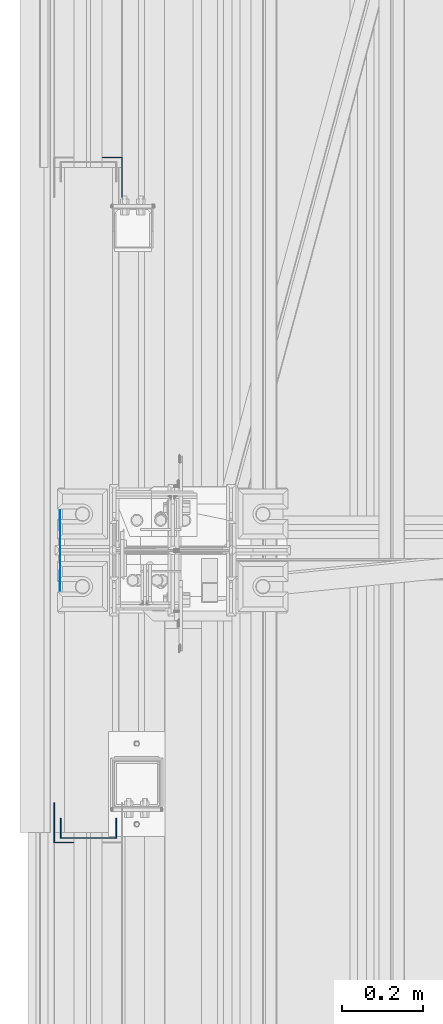
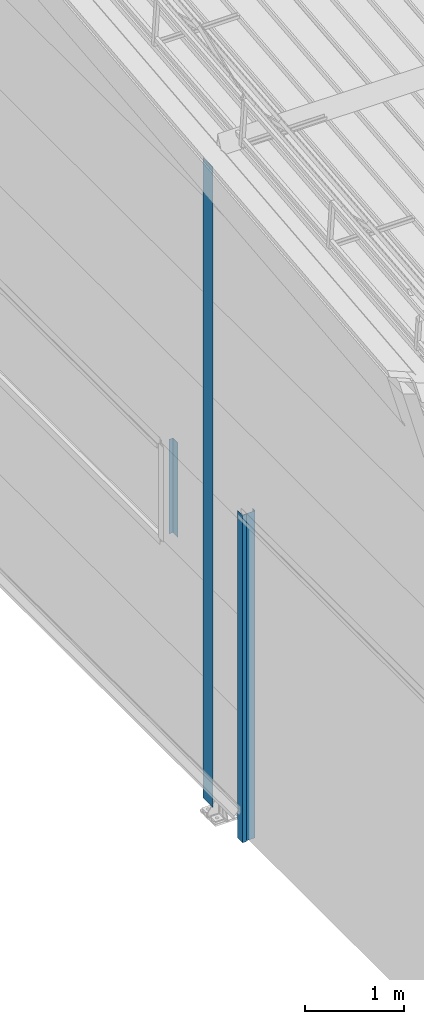
# One storey, part 2 of 709: 4 columns, 4 elements without a shape of their own.
"""IFC4 building model written with IfcOpenShell, lengths in millimetres."""

from ifc_helpers import new_model, si_unit, direction, frame, origin_with_axes, place, context, subcontext, project, spatial, line, indexed_curve, outline, extrude, material, element, aggregate, save


model = new_model("IFC4")

# Units and contexts
model_context = context("Model", 3, precision=0.2, world=origin_with_axes(), true_north=direction((0.0, 1.0)))
body_context = subcontext(model_context, "Body", "Model", "MODEL_VIEW")
ifc_project = project(units=[si_unit("LENGTHUNIT", "METRE", prefix="MILLI"), si_unit("AREAUNIT", "SQUARE_METRE"), si_unit("VOLUMEUNIT", "CUBIC_METRE"), si_unit("MASSUNIT", "GRAM", prefix="KILO"), si_unit("TIMEUNIT", "SECOND"), si_unit("PLANEANGLEUNIT", "RADIAN"), si_unit("SOLIDANGLEUNIT", "STERADIAN"), si_unit("THERMODYNAMICTEMPERATUREUNIT", "DEGREE_CELSIUS"), si_unit("LUMINOUSINTENSITYUNIT", "LUMEN")], contexts=[model_context])

# Site, building, storey
site_placement = place(None, origin_with_axes())
site = spatial("IfcSite", under=ifc_project, at=site_placement, CompositionType="ELEMENT")
building_placement = place(site_placement, origin_with_axes())
building = spatial("IfcBuilding", under=site, at=building_placement, Name="Undefined", CompositionType="ELEMENT")
storey_placement = place(building_placement, origin_with_axes())
storey = spatial("IfcBuildingStorey", under=building, at=storey_placement, Name="Undefined", CompositionType="ELEMENT", Elevation=0.0)

# Assembly, column
assembly_1_placement = place(storey_placement, frame((-60.0, 4810.0, -50.0), z_axis=(1.0, 0.0, 0.0), x_axis=(0.0, 0.0, 1.0)))
assembly_1 = element("IfcElementAssembly", 1, at=assembly_1_placement, inside=storey)
ifc_material = material(Name="Steel_Undefined", Category="STEEL")
column_1_placement = place(assembly_1_placement, origin_with_axes())
column_1 = element("IfcColumn", 2, at=column_1_placement, material=ifc_material, context=body_context, shape_type="SolidModel", body=[
    extrude(outline(indexed_curve([(-70.0, -25.0), (-68.0, -25.0), (-68.0, 23.0), (68.0, 23.0), (68.0, -25.0), (70.0, -25.0), (70.0, 25.0), (-70.0, 25.0)], segments=[line(1, 2, 3, 4, 5, 6, 7, 8, 1)])), frame((0.0, 0.0, 0.0), z_axis=(-1.0, 0.0, 0.0), x_axis=(0.0, 0.0, 1.0)), (0.0, 0.0, -1.0), 4050.0),
])
aggregate(assembly_1, [column_1])

assembly_2_placement = place(storey_placement, frame((-121.0, 4775.0, -50.0), z_axis=(-1.0, 0.0, 0.0), x_axis=(0.0, 0.0, 1.0)))
assembly_2 = element("IfcElementAssembly", 3, at=assembly_2_placement, inside=storey)
column_2_placement = place(assembly_2_placement, origin_with_axes())
column_2 = element("IfcColumn", 4, at=column_2_placement, material=ifc_material, context=body_context, shape_type="SolidModel", body=[
    extrude(outline(indexed_curve([(-25.0, -1.0), (25.0, -1.0), (25.0, 99.0), (23.0, 99.0), (23.0, 1.0), (-25.0, 1.0)], segments=[line(1, 2, 3, 4, 5, 6, 1)])), frame((0.0, 0.0, 0.0), z_axis=(-1.0, 0.0, 0.0), x_axis=(0.0, 0.0, 1.0)), (0.0, 0.0, -1.0), 4050.0),
])
aggregate(assembly_2, [column_2])

assembly_3_placement = place(storey_placement, frame((-1.0, 6475.0, 2700.0), z_axis=(1.0, 0.0, 0.0), x_axis=(0.0, 0.0, 1.0)))
assembly_3 = element("IfcElementAssembly", 5, at=assembly_3_placement, inside=storey)
column_3_placement = place(assembly_3_placement, origin_with_axes())
column_3 = element("IfcColumn", 6, at=column_3_placement, material=ifc_material, context=body_context, shape_type="SolidModel", body=[
    extrude(outline(indexed_curve([(-25.0, -1.0), (25.0, -1.0), (25.0, 99.0), (23.0, 99.0), (23.0, 1.0), (-25.0, 1.0)], segments=[line(1, 2, 3, 4, 5, 6, 1)])), frame((0.0, 0.0, 0.0), z_axis=(-1.0, 0.0, 0.0), x_axis=(0.0, 0.0, 1.0)), (0.0, 0.0, -1.0), 1170.0),
])
aggregate(assembly_3, [column_3])

assembly_4_placement = place(storey_placement, frame((-130.0, 5500.0, 0.0), z_axis=(-1.0, 0.0, 0.0), x_axis=(0.0, 0.0, 1.0)))
assembly_4 = element("IfcElementAssembly", 7, at=assembly_4_placement, inside=storey)
column_4_placement = place(assembly_4_placement, origin_with_axes())
column_4 = element("IfcColumn", 8, at=column_4_placement, material=ifc_material, context=body_context, shape_type="SolidModel", body=[
    extrude(outline(indexed_curve([(-0.375, -100.0), (1.245, -100.0), (1.245, -50.0), (0.495, -50.0), (0.495, -99.25), (0.375, -99.25), (0.375, 99.25), (0.495, 99.25), (0.495, 50.0), (1.245, 50.0), (1.245, 100.0), (-0.375, 100.0)], segments=[line(1, 2, 3, 4, 5, 6, 7, 8, 9, 10, 11, 12, 1)])), frame((0.0, 0.0, 0.0), z_axis=(-1.0, 0.0, 0.0), x_axis=(0.0, 0.0, 1.0)), (0.0, 0.0, -1.0), 7929.67111),
])
aggregate(assembly_4, [column_4])

save(model, "model.ifc")
